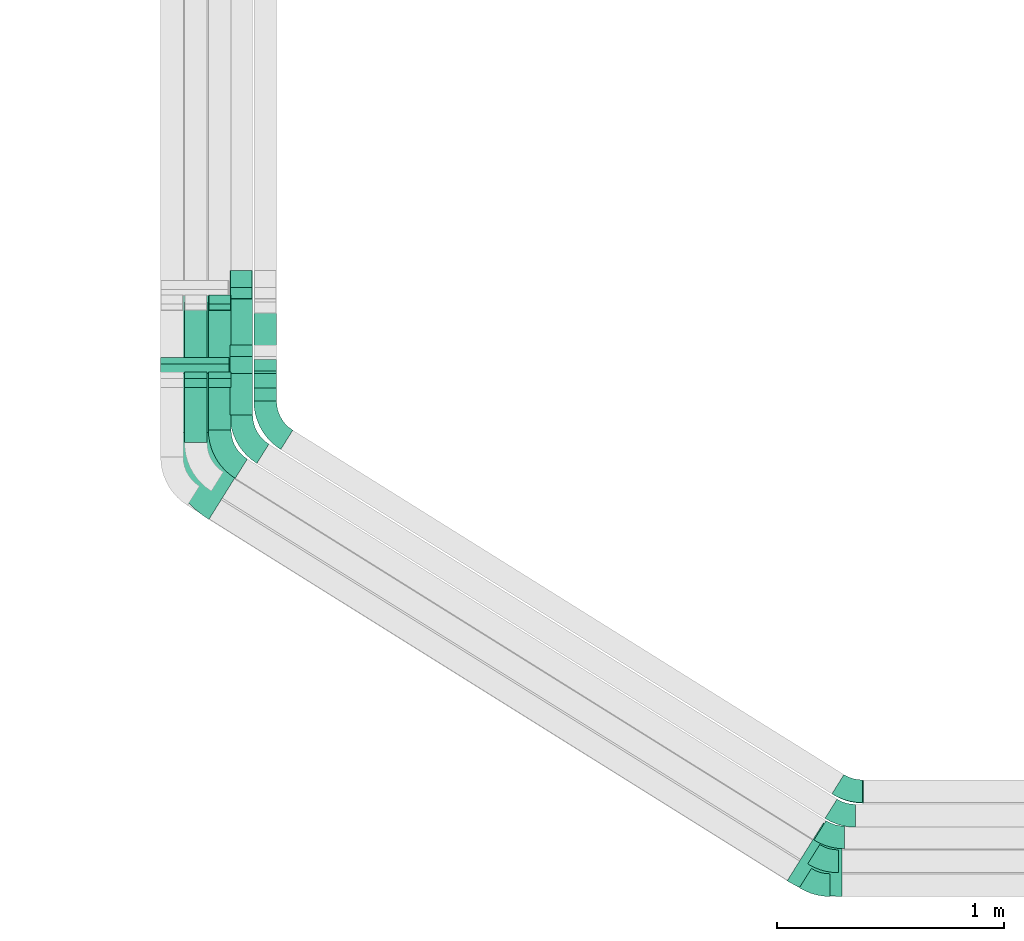
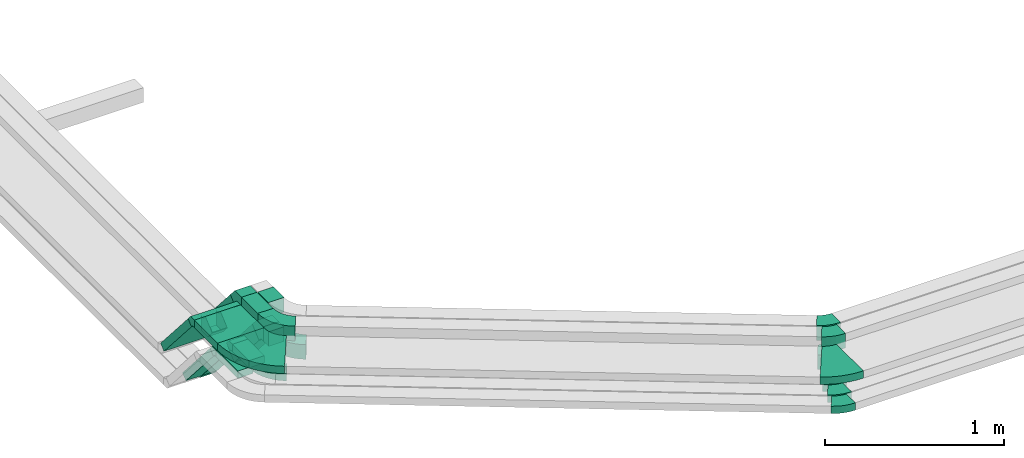
# One storey, part 4 of 18: 18 flow fittings, 11 flow segments.
"""IFC2X3 building model written with IfcOpenShell, lengths in millimetres."""

from ifc_helpers import new_model, entity, si_unit, converted_unit, derived_unit, direction, frame, frame_2d, origin, origin_2d_with_axis, place, context, subcontext, project, spatial, polyline, circle_curve, parameter, trimmed, segment, composite_curve, rectangle, outline, extrude, faceted_brep, source, transform, mapped, material, type_object, type_shapes, element, save


model = new_model("IFC2X3")

# Units and contexts
model_context = context("Model", 3, precision=0.01, world=origin(), true_north=direction((6.12303176911189e-17, 1.0)))
body_context = subcontext(model_context, "Body", "Model", "MODEL_VIEW")
ifc_project = project(units=[si_unit("LENGTHUNIT", "METRE", prefix="MILLI"), si_unit("AREAUNIT", "SQUARE_METRE"), si_unit("VOLUMEUNIT", "CUBIC_METRE"), converted_unit("PLANEANGLEUNIT", "DEGREE", entity("IfcRatioMeasure", 0.0174532925199433), si_unit("PLANEANGLEUNIT", "RADIAN"), dimensions=[0, 0, 0, 0, 0, 0, 0]), si_unit("MASSUNIT", "GRAM", prefix="KILO"), derived_unit("MASSDENSITYUNIT", [(si_unit("MASSUNIT", "GRAM", prefix="KILO"), 1), (si_unit("LENGTHUNIT", "METRE"), -3)]), derived_unit("MOMENTOFINERTIAUNIT", [(si_unit("LENGTHUNIT", "METRE"), 4)]), si_unit("TIMEUNIT", "SECOND"), si_unit("FREQUENCYUNIT", "HERTZ"), si_unit("THERMODYNAMICTEMPERATUREUNIT", "DEGREE_CELSIUS"), derived_unit("THERMALTRANSMITTANCEUNIT", [(si_unit("MASSUNIT", "GRAM", prefix="KILO"), 1), (si_unit("THERMODYNAMICTEMPERATUREUNIT", "KELVIN"), -1), (si_unit("TIMEUNIT", "SECOND"), -3)]), derived_unit("VOLUMETRICFLOWRATEUNIT", [(si_unit("LENGTHUNIT", "METRE"), 3), (si_unit("TIMEUNIT", "SECOND"), -1)]), derived_unit("MASSFLOWRATEUNIT", [(si_unit("MASSUNIT", "GRAM", prefix="KILO"), 1), (si_unit("TIMEUNIT", "SECOND"), -1)]), derived_unit("ROTATIONALFREQUENCYUNIT", [(si_unit("TIMEUNIT", "SECOND"), -1)]), si_unit("ELECTRICCURRENTUNIT", "AMPERE"), si_unit("ELECTRICVOLTAGEUNIT", "VOLT"), si_unit("POWERUNIT", "WATT"), si_unit("FORCEUNIT", "NEWTON", prefix="KILO"), si_unit("ILLUMINANCEUNIT", "LUX"), si_unit("LUMINOUSFLUXUNIT", "LUMEN"), si_unit("LUMINOUSINTENSITYUNIT", "CANDELA"), derived_unit("USERDEFINED", [(si_unit("MASSUNIT", "GRAM", prefix="KILO"), -1), (si_unit("LENGTHUNIT", "METRE"), -2), (si_unit("TIMEUNIT", "SECOND"), 3), (si_unit("LUMINOUSFLUXUNIT", "LUMEN"), 1)]), derived_unit("LINEARVELOCITYUNIT", [(si_unit("LENGTHUNIT", "METRE"), 1), (si_unit("TIMEUNIT", "SECOND"), -1)]), si_unit("PRESSUREUNIT", "PASCAL"), derived_unit("USERDEFINED", [(si_unit("LENGTHUNIT", "METRE"), -2), (si_unit("MASSUNIT", "GRAM", prefix="KILO"), 1), (si_unit("TIMEUNIT", "SECOND"), -2)]), derived_unit("LINEARFORCEUNIT", [(si_unit("MASSUNIT", "GRAM", prefix="KILO"), 1), (si_unit("LENGTHUNIT", "METRE"), 1), (si_unit("TIMEUNIT", "SECOND"), -2), (si_unit("LENGTHUNIT", "METRE"), -1)]), derived_unit("PLANARFORCEUNIT", [(si_unit("MASSUNIT", "GRAM", prefix="KILO"), 1), (si_unit("LENGTHUNIT", "METRE"), 1), (si_unit("TIMEUNIT", "SECOND"), -2), (si_unit("LENGTHUNIT", "METRE"), -2)])], contexts=[model_context])

# Site, building, storey
site_placement = place(None, frame((0.0, -0.00077364408347762, 0.0)))
site = spatial("IfcSite", under=ifc_project, at=site_placement, CompositionType="ELEMENT")
building_placement = place(site_placement, origin())
building = spatial("IfcBuilding", under=site, at=building_placement, CompositionType="ELEMENT")
storey_placement = place(building_placement, frame((0.0, 0.0, 19800.0)))
storey = spatial("IfcBuildingStorey", under=building, at=storey_placement, CompositionType="ELEMENT", Elevation=19800.0)

# Flow segments
cable_carrier_segment_type = type_object("IfcCableCarrierSegmentType", PredefinedType="CABLETRAYSEGMENT")
flow_segment_1_placement = place(storey_placement, frame((18112.1440474966, 4082.6181847776, 3000.0)))
element("IfcFlowSegment", 1, at=flow_segment_1_placement, inside=storey, type_object=cable_carrier_segment_type, context=body_context, shape_type="SweptSolid", body=[
    extrude(rectangle(XDim=241.620714461309, YDim=99.9999999999989, at=frame_2d((0.0, -1.08357767203415e-12), x_axis=(1.0, 0.0))), frame((50.0, 120.81035723066, 0.0), z_axis=(0.0, 0.0, 1.0), x_axis=(0.0, 1.0, 0.0)), (0.0, 0.0, 1.0), 49.9999999999973),
])
flow_segment_2_placement = place(storey_placement, frame((18217.1440474966, 4139.24926094307, 3000.0)))
element("IfcFlowSegment", 2, at=flow_segment_2_placement, inside=storey, type_object=cable_carrier_segment_type, context=body_context, shape_type="SweptSolid", body=[
    extrude(rectangle(XDim=184.989638295838, YDim=99.9999999999989, at=frame_2d((0.0, -1.08357767203415e-12), x_axis=(1.0, 0.0))), frame((50.0, 92.4948191479257, 0.0), z_axis=(0.0, 0.0, 1.0), x_axis=(0.0, 1.0, 0.0)), (0.0, 0.0, 1.0), 49.999999999993),
])
flow_segment_3_placement = place(storey_placement, frame((18417.1440474966, 4266.16565358375, 3000.0)))
element("IfcFlowSegment", 3, at=flow_segment_3_placement, inside=storey, type_object=cable_carrier_segment_type, context=body_context, shape_type="SweptSolid", body=[
    extrude(rectangle(XDim=57.0191013239463, YDim=99.9999999999989, at=frame_2d((2.70006239588838e-13, 1.08357767203415e-12), x_axis=(1.0, 0.0))), frame((50.0, 28.5095506619832, 0.0), z_axis=(0.0, 0.0, 1.0), x_axis=(0.0, 1.0, 0.0)), (0.0, 0.0, 1.0), 100.000000000008),
])
flow_segment_4_placement = place(storey_placement, frame((18112.1440474966, 4355.16048179056, 2631.28882558187)))
element("IfcFlowSegment", 4, at=flow_segment_4_placement, inside=storey, type_object=cable_carrier_segment_type, context=body_context, shape_type="SweptSolid", body=[
    extrude(rectangle(XDim=49.999999999999, YDim=99.9999999999989, at=frame_2d((-2.04281036531029e-13, 0.0), x_axis=(1.0, 0.0))), frame((50.0, 327.133678626219, 16.4014757247622), z_axis=(0.0, -0.656059028990503, 0.754709580222776), x_axis=(0.0, 0.754709580222776, 0.656059028990503)), (0.0, 0.0, 1.0), 469.87530923093),
])
flow_segment_5_placement = place(storey_placement, frame((18217.1440474966, 4355.16048179056, 2631.28882558187)))
element("IfcFlowSegment", 5, at=flow_segment_5_placement, inside=storey, type_object=cable_carrier_segment_type, context=body_context, shape_type="SweptSolid", body=[
    extrude(rectangle(XDim=49.999999999999, YDim=99.9999999999989, at=frame_2d((-2.04281036531029e-13, 2.16715534406831e-12), x_axis=(1.0, 0.0))), frame((50.0, 327.133678626218, 16.4014757247622), z_axis=(0.0, -0.656059028990503, 0.754709580222776), x_axis=(0.0, 0.754709580222776, 0.656059028990503)), (0.0, 0.0, 1.0), 469.87530923093),
])
flow_segment_6_placement = place(storey_placement, frame((18417.1440474966, 4372.97407696492, 2657.08439840759)))
element("IfcFlowSegment", 6, at=flow_segment_6_placement, inside=storey, type_object=cable_carrier_segment_type, context=body_context, shape_type="SweptSolid", body=[
    extrude(rectangle(XDim=99.9999999999987, YDim=99.9999999999989, at=origin_2d_with_axis()), frame((50.0, 316.103085662766, 32.8029514495245), z_axis=(0.0, -0.656059028990498, 0.75470958022278), x_axis=(0.0, 0.75470958022278, 0.656059028990498)), (0.0, 0.0, 1.0), 424.302683677664),
])
flow_segment_7_placement = place(storey_placement, frame((18007.1440474966, 4128.04598957686, 3200.0)))
element("IfcFlowSegment", 7, at=flow_segment_7_placement, inside=storey, type_object=cable_carrier_segment_type, context=body_context, shape_type="SweptSolid", body=[
    extrude(rectangle(XDim=259.517993750342, YDim=300.000000000001, at=origin_2d_with_axis()), frame((150.0, 129.758996875171, 0.0), z_axis=(0.0, 0.0, 1.0), x_axis=(0.0, 1.0, 0.0)), (0.0, 0.0, 1.0), 49.9999999999973),
])
flow_segment_8_placement = place(storey_placement, frame((18007.1440474966, 4418.48556587883, 2831.28882558187)))
element("IfcFlowSegment", 8, at=flow_segment_8_placement, inside=storey, type_object=cable_carrier_segment_type, context=body_context, shape_type="SweptSolid", body=[
    extrude(rectangle(XDim=49.999999999999, YDim=300.000000000001, at=frame_2d((4.10338429901458e-13, 0.0), x_axis=(1.0, 0.0))), frame((150.0, 327.133678626233, 16.4014757247709), z_axis=(0.0, -0.656059028990503, 0.754709580222776), x_axis=(0.0, 0.754709580222776, 0.656059028990503)), (0.0, 0.0, 1.0), 469.875309230929),
])
flow_segment_9_placement = place(storey_placement, frame((18312.1440474966, 4205.09736371012, 3200.0)))
element("IfcFlowSegment", 9, at=flow_segment_9_placement, inside=storey, type_object=cable_carrier_segment_type, context=body_context, shape_type="SweptSolid", body=[
    extrude(rectangle(XDim=181.412475285859, YDim=99.9999999999989, at=frame_2d((2.70006239588838e-13, 0.0), x_axis=(1.0, 0.0))), frame((50.0, 90.706237642931, 0.0), z_axis=(0.0, 0.0, 1.0), x_axis=(0.0, 1.0, 0.0)), (0.0, 0.0, 1.0), 100.000000000003),
])
flow_segment_10_placement = place(storey_placement, frame((18312.1440474966, 4436.29916105319, 2857.08439840759)))
element("IfcFlowSegment", 10, at=flow_segment_10_placement, inside=storey, type_object=cable_carrier_segment_type, context=body_context, shape_type="SweptSolid", body=[
    extrude(rectangle(XDim=99.9999999999979, YDim=99.9999999999989, at=origin_2d_with_axis()), frame((50.0, 316.103085662771, 32.8029514495245), z_axis=(0.0, -0.656059028990503, 0.754709580222776), x_axis=(0.0, 0.754709580222776, 0.656059028990503)), (0.0, 0.0, 1.0), 424.302683677666),
])
flow_segment_11_placement = place(storey_placement, frame((18417.1440474966, 4266.16565358379, 3200.0)))
element("IfcFlowSegment", 11, at=flow_segment_11_placement, inside=storey, type_object=cable_carrier_segment_type, context=body_context, shape_type="SweptSolid", body=[
    extrude(rectangle(XDim=120.344185412181, YDim=99.9999999999989, at=frame_2d((2.70006239588838e-13, 0.0), x_axis=(1.0, 0.0))), frame((50.0, 60.1720927060936, 0.0), z_axis=(0.0, 0.0, 1.0), x_axis=(0.0, 1.0, 0.0)), (0.0, 0.0, 1.0), 100.000000000008),
])

# Flow fittings
ifc_material = material()
cable_carrier_fitting_type_1 = type_object("IfcCableCarrierFittingType", Name="470_DKC_S5_Variable Angle Elbow 0-45:-", PredefinedType="NOTDEFINED", material=ifc_material)
shared_shape_1 = source(origin(), body_context, "Body", "SweptSolid", [
    extrude(outline(composite_curve([segment(polyline([(-53.9539384473602, -65.3276702004164), (-52.9539384473589, -65.3276702004164)]), True, "CONTINUOUS"), segment(trimmed(circle_curve(frame_2d((-52.9539384473615, 184.672329799583), x_axis=(0.0, -1.0)), 250.0), [parameter(0.0)], [parameter(32.0000000000001)], True, "PARAMETER"), True, "CONTINUOUS"), segment(polyline([(79.5258776109423, -27.3396942395212), (80.3739257070985, -26.8097749752882)]), True, "CONTINUOUS"), segment(polyline([(80.3739257070985, -26.8097749752881), (27.3819992837774, 57.995034640354)]), True, "CONTINUOUS"), segment(polyline([(27.3819992837774, 57.995034640354), (26.5339511876208, 57.4651153761206)]), True, "CONTINUOUS"), segment(trimmed(circle_curve(frame_2d((-52.9539384473615, 184.672329799583), x_axis=(0.0, -1.0)), 150.0), [parameter(0.0)], [parameter(32.0000000000001)], True, "PARAMETER"), False, "CONTINUOUS"), segment(polyline([(-52.9539384473597, 34.6723297995835), (-53.953938447361, 34.6723297995835)]), True, "CONTINUOUS"), segment(polyline([(-53.953938447361, 34.6723297995835), (-53.9539384473602, -65.3276702004164)]), True, "CONTINUOUS")], self_intersect=False)), frame((-4.39513870439234, 15.3276702004079, -50.0)), (0.0, 0.0, 1.0), 100.0),
])
type_shapes(cable_carrier_fitting_type_1, [shared_shape_1])
for number, where, z_axis, x_axis, name in (
    (12, (21038.9389178804, 2547.26804939277, 3050.0), (0.0, 0.0, 1.0), (0.848048096156425, -0.529919264233207, 0.0), "470_DKC_S5_Variable Angle Elbow 0-45:-"),
    (13, (21004.2443505154, 2442.26804939278, 3250.0), (0.0, 0.0, 1.0), (0.848048096156423, -0.52991926423321, 0.0), "470_DKC_S5_Variable Angle Elbow 0-45:-"),
    (14, (21034.567045744, 2549.99989830126, 3250.0), (0.0, 0.0, 1.0), (0.848048096156423, -0.52991926423321, 0.0), "470_DKC_S5_Variable Angle Elbow 0-45:-"),
):
    element("IfcFlowFitting", number, at=place(storey_placement, frame(where, z_axis=z_axis, x_axis=x_axis)), inside=storey, type_object=cable_carrier_fitting_type_1, material=ifc_material, Name=name, ObjectType="470_DKC_S5_Variable Angle Elbow 0-45:-", context=body_context, shape_type="MappedRepresentation", body=[
        mapped(shared_shape_1, transform((0.0, 0.0, 0.0), scale=1.0)),
    ])
cable_carrier_fitting_type_2 = type_object("IfcCableCarrierFittingType", Name="470_DKC_S5_Variable Angle Elbow 0-45:-", PredefinedType="NOTDEFINED", material=ifc_material)
shared_shape_2 = source(origin(), body_context, "Body", "SweptSolid", [
    extrude(outline(composite_curve([segment(polyline([(-53.9539384473611, -65.3276702004161), (-52.9539384473598, -65.3276702004161)]), True, "CONTINUOUS"), segment(trimmed(circle_curve(frame_2d((-52.9539384473602, 184.672329799584), x_axis=(0.0, -1.0)), 250.0), [parameter(0.0)], [parameter(32.0000000000003)], True, "PARAMETER"), True, "CONTINUOUS"), segment(polyline([(79.5258776109425, -27.3396942395216), (80.3739257070989, -26.8097749752884)]), True, "CONTINUOUS"), segment(polyline([(80.3739257070989, -26.8097749752884), (27.3819992837779, 57.9950346403538)]), True, "CONTINUOUS"), segment(polyline([(27.3819992837779, 57.9950346403537), (26.5339511876214, 57.4651153761205)]), True, "CONTINUOUS"), segment(trimmed(circle_curve(frame_2d((-52.9539384473602, 184.672329799584), x_axis=(0.0, -1.0)), 150.0), [parameter(0.0)], [parameter(32.0000000000003)], True, "PARAMETER"), False, "CONTINUOUS"), segment(polyline([(-52.9539384473598, 34.6723297995838), (-53.9539384473611, 34.6723297995838)]), True, "CONTINUOUS"), segment(polyline([(-53.9539384473611, 34.6723297995838), (-53.9539384473611, -65.3276702004161)]), True, "CONTINUOUS")], self_intersect=False)), frame((-4.39513870439244, 15.327670200408, -25.0)), (0.0, 0.0, 1.0), 50.0),
])
type_shapes(cable_carrier_fitting_type_2, [shared_shape_2])
for number, where, z_axis, x_axis, name in (
    (15, (20955.8971382444, 2347.26804939277, 3025.0), (0.0, 0.0, 1.0), (0.848048096156423, -0.52991926423321, 0.0), "470_DKC_S5_Variable Angle Elbow 0-45:-"),
    (16, (20928.3035971894, 2242.26804939277, 3025.0), (0.0, 0.0, 1.0), (0.848048096156423, -0.52991926423321, 0.0), "470_DKC_S5_Variable Angle Elbow 0-45:-"),
    (17, (20891.6866703417, 2137.26804939277, 3025.0), (0.0, 0.0, 1.0), (0.848048096156423, -0.52991926423321, 0.0), "470_DKC_S5_Variable Angle Elbow 0-45:-"),
):
    element("IfcFlowFitting", number, at=place(storey_placement, frame(where, z_axis=z_axis, x_axis=x_axis)), inside=storey, type_object=cable_carrier_fitting_type_2, material=ifc_material, Name=name, ObjectType="470_DKC_S5_Variable Angle Elbow 0-45:-", context=body_context, shape_type="MappedRepresentation", body=[
        mapped(shared_shape_2, transform((0.0, 0.0, 0.0), scale=1.0)),
    ])
cable_carrier_fitting_type_3 = type_object("IfcCableCarrierFittingType", Name="470_DKC_S5_Variable Angle Elbow 0-45:-", PredefinedType="NOTDEFINED", material=ifc_material)
shared_shape_3 = source(origin(), body_context, "Body", "SweptSolid", [
    extrude(outline(composite_curve([segment(polyline([(-80.4499016590186, -172.925265392596), (-79.4499016590172, -172.925265392596)]), True, "CONTINUOUS"), segment(trimmed(circle_curve(frame_2d((-79.4499016590253, 277.074734607403), x_axis=(0.0, -1.0)), 450.0), [parameter(0.0)], [parameter(32.0000000000003)], True, "PARAMETER"), True, "CONTINUOUS"), segment(polyline([(159.013767245926, -104.546908662982), (159.861815342083, -104.016989398749)]), True, "CONTINUOUS"), segment(polyline([(159.861815342083, -104.016989398749), (0.886036072114065, 150.397439448174)]), True, "CONTINUOUS"), segment(polyline([(0.886036072114098, 150.397439448174), (0.03798797595827, 149.867520183942)]), True, "CONTINUOUS"), segment(trimmed(circle_curve(frame_2d((-79.4499016590253, 277.074734607403), x_axis=(0.0, -1.0)), 150.0), [parameter(0.0)], [parameter(32.0000000000003)], True, "PARAMETER"), False, "CONTINUOUS"), segment(polyline([(-79.4499016590223, 127.074734607404), (-80.4499016590237, 127.074734607404)]), True, "CONTINUOUS"), segment(polyline([(-80.4499016590237, 127.074734607404), (-80.4499016590186, -172.925265392596)]), True, "CONTINUOUS")], self_intersect=False)), frame((-6.57371406861295, 22.9252653925868, -25.0)), (0.0, 0.0, 1.0), 49.9999999999987),
])
type_shapes(cable_carrier_fitting_type_3, [shared_shape_3])
flow_fitting_1_placement = place(storey_placement, frame((20915.2969629533, 2237.26804939276, 3225.0), z_axis=(0.0, 0.0, 1.0), x_axis=(0.848048096156423, -0.529919264233209, 0.0)))
element("IfcFlowFitting", 18, at=flow_fitting_1_placement, inside=storey, type_object=cable_carrier_fitting_type_3, material=ifc_material, Name="470_DKC_S5_Variable Angle Elbow 0-45:-", ObjectType="470_DKC_S5_Variable Angle Elbow 0-45:-", context=body_context, shape_type="MappedRepresentation", body=[
    mapped(shared_shape_3, transform((0.0, 0.0, 0.0), scale=1.0)),
])
cable_carrier_fitting_type_4 = type_object("IfcCableCarrierFittingType", Name="470_DKC_S5_Variable Angle Elbow 0-45:-", PredefinedType="NOTDEFINED", material=ifc_material)
shared_shape_4 = source(origin(), body_context, "Body", "SweptSolid", [
    extrude(outline(composite_curve([segment(polyline([(-85.6872894317013, -97.2200856007182), (-84.6872894317002, -97.2200856007182)]), True, "CONTINUOUS"), segment(trimmed(circle_curve(frame_2d((-84.6872894317005, 152.779914399281), x_axis=(0.0, -1.0)), 250.0), [parameter(0.0)], [parameter(57.9999999999997)], True, "PARAMETER"), True, "CONTINUOUS"), segment(polyline([(127.324734607405, 20.3000983409794), (127.854653871638, 21.1481464371359)]), True, "CONTINUOUS"), segment(polyline([(127.854653871638, 21.1481464371359), (43.049844255996, 74.1400728604566)]), True, "CONTINUOUS"), segment(polyline([(43.049844255996, 74.1400728604566), (42.5199249917629, 73.2920247643002)]), True, "CONTINUOUS"), segment(trimmed(circle_curve(frame_2d((-84.6872894317005, 152.779914399281), x_axis=(0.0, -1.0)), 150.0), [parameter(0.0)], [parameter(57.9999999999997)], True, "PARAMETER"), False, "CONTINUOUS"), segment(polyline([(-84.6872894317002, 2.77991439928172), (-85.6872894317013, 2.77991439928172)]), True, "CONTINUOUS"), segment(polyline([(-85.6872894317013, 2.77991439928172), (-85.6872894317013, -97.2200856007182)]), True, "CONTINUOUS")], self_intersect=False)), frame((-26.1745208588429, 47.2200856007101, -25.0)), (0.0, 0.0, 1.0), 49.9999999999998),
])
type_shapes(cable_carrier_fitting_type_4, [shared_shape_4])
flow_fitting_2_placement = place(storey_placement, frame((18267.1440474966, 4027.38745065254, 3025.0), z_axis=(0.0, 0.0, 1.0), x_axis=(0.0, -1.0, 0.0)))
element("IfcFlowFitting", 19, at=flow_fitting_2_placement, inside=storey, type_object=cable_carrier_fitting_type_4, material=ifc_material, Name="470_DKC_S5_Variable Angle Elbow 0-45:-", ObjectType="470_DKC_S5_Variable Angle Elbow 0-45:-", context=body_context, shape_type="MappedRepresentation", body=[
    mapped(shared_shape_4, transform((0.0, 0.0, 0.0), scale=1.0)),
])
cable_carrier_fitting_type_5 = type_object("IfcCableCarrierFittingType", PredefinedType="NOTDEFINED", material=ifc_material)
shared_shape_5 = source(origin(), body_context, "Body", "Brep", [
    faceted_brep([(-30.0649440542927, -25.0, 50.0), (-30.0649440542926, 25.0, 50.0), (-30.0649440542926, 25.0, 47.4600000101635), (-30.0649440542927, -22.4600000101599, 47.4600000101635), (-30.0649440542927, -22.4600000101599, -47.4600000101565), (-30.0649440542926, 25.0, -47.4600000101565), (-30.0649440542926, 25.0, -50.0), (-30.0649440542927, -25.0, -50.0), (38.5921175084832, 6.28882558187459, 50.0), (38.5921175084832, 6.28882558187459, -50.0), (0.856638497343776, 39.091777031399, -50.0), (0.856638497343783, 39.091777031399, -47.4600000101565), (36.6751551823852, 7.95521550884487, -47.4600000101565), (36.6751551823852, 7.95521550884487, 47.4600000101635), (0.856638497343774, 39.091777031399, 47.4600000101635), (0.85663849734377, 39.091777031399, 50.0), (11.3931563883155, -25.0, 50.0), (-11.3931563883146, 25.0, 50.0), (-11.3931563883146, 25.0, 47.4600000101635), (10.2356117038927, -22.46000001016, 47.4600000101635), (10.2356117038927, -22.46000001016, -47.4600000101565), (-11.3931563883146, 25.0, -47.4600000101565), (-11.3931563883146, 25.0, -50.0), (11.3931563883153, -25.0, -50.0)], [[[0, 1, 2, 3, 4, 5, 6, 7]], [[8, 9, 10, 11, 12, 13, 14, 15]], [[1, 0, 16, 8, 15, 17]], [[2, 1, 17, 18]], [[3, 2, 18, 14, 13, 19]], [[4, 3, 19, 20]], [[5, 4, 20, 12, 11, 21]], [[6, 5, 21, 22]], [[7, 6, 22, 10, 9, 23]], [[0, 7, 23, 16]], [[18, 17, 15, 14]], [[20, 19, 13, 12]], [[22, 21, 11, 10]], [[16, 23, 9, 8]]]),
])
type_shapes(cable_carrier_fitting_type_5, [shared_shape_5])
for number, where, z_axis, x_axis in (
    (20, (18162.1440474966, 4354.30384329322, 3025.0), (1.0, 0.0, 0.0), (0.0, -0.656059028990493, 0.754709580222785)),
    (21, (18267.1440474966, 4354.30384329322, 3025.0), (1.0, 0.0, 0.0), (0.0, -0.656059028990493, 0.754709580222785)),
    (22, (18267.1440474966, 4702.01853841969, 2625.0), (1.0, 0.0, 0.0), (0.0, 0.656059028990493, -0.754709580222785)),
):
    element("IfcFlowFitting", number, at=place(storey_placement, frame(where, z_axis=z_axis, x_axis=x_axis)), inside=storey, type_object=cable_carrier_fitting_type_5, material=ifc_material, context=body_context, shape_type="MappedRepresentation", body=[
        mapped(shared_shape_5, transform((0.0, 0.0, 0.0), scale=1.0)),
    ])
cable_carrier_fitting_type_6 = type_object("IfcCableCarrierFittingType", Name="470_DKC_S5_Variable Angle Elbow 0-45:-", PredefinedType="NOTDEFINED", material=ifc_material)
shared_shape_6 = source(origin(), body_context, "Body", "SweptSolid", [
    extrude(outline(composite_curve([segment(polyline([(-85.6872894317007, -97.2200856007192), (-84.6872894316995, -97.2200856007192)]), True, "CONTINUOUS"), segment(trimmed(circle_curve(frame_2d((-84.687289431702, 152.77991439928), x_axis=(0.0, -1.0)), 250.0), [parameter(0.0)], [parameter(57.9999999999999)], True, "PARAMETER"), True, "CONTINUOUS"), segment(polyline([(127.324734607405, 20.3000983409809), (127.854653871638, 21.1481464371369)]), True, "CONTINUOUS"), segment(polyline([(127.854653871638, 21.1481464371369), (43.0498442559958, 74.1400728604577)]), True, "CONTINUOUS"), segment(polyline([(43.0498442559958, 74.1400728604576), (42.5199249917623, 73.2920247643008)]), True, "CONTINUOUS"), segment(trimmed(circle_curve(frame_2d((-84.687289431702, 152.77991439928), x_axis=(0.0, -1.0)), 150.0), [parameter(0.0)], [parameter(57.9999999999999)], True, "PARAMETER"), False, "CONTINUOUS"), segment(polyline([(-84.6872894317004, 2.77991439928066), (-85.6872894317016, 2.77991439928066)]), True, "CONTINUOUS"), segment(polyline([(-85.6872894317016, 2.77991439928066), (-85.6872894317007, -97.2200856007192)]), True, "CONTINUOUS")], self_intersect=False)), frame((-26.1745208588432, 47.2200856007104, -50.0)), (0.0, 0.0, 1.0), 100.0),
])
type_shapes(cable_carrier_fitting_type_6, [shared_shape_6])
for number, where, z_axis, x_axis, name in (
    (23, (18467.1440474966, 4154.30384329322, 3050.0), (0.0, 0.0, 1.0), (0.0, -1.0, 0.0), "470_DKC_S5_Variable Angle Elbow 0-45:-"),
    (24, (18362.1440474966, 4093.23555341958, 3250.0), (0.0, 0.0, 1.0), (0.0, -1.0, 0.0), "470_DKC_S5_Variable Angle Elbow 0-45:-"),
):
    element("IfcFlowFitting", number, at=place(storey_placement, frame(where, z_axis=z_axis, x_axis=x_axis)), inside=storey, type_object=cable_carrier_fitting_type_6, material=ifc_material, Name=name, ObjectType="470_DKC_S5_Variable Angle Elbow 0-45:-", context=body_context, shape_type="MappedRepresentation", body=[
        mapped(shared_shape_6, transform((0.0, 0.0, 0.0), scale=1.0)),
    ])
cable_carrier_fitting_type_7 = type_object("IfcCableCarrierFittingType", PredefinedType="NOTDEFINED", material=ifc_material)
shared_shape_7 = source(origin(), body_context, "Body", "Brep", [
    faceted_brep([(-52.8512568309224, -50.0, 50.0), (-52.851256830922, 50.0, 50.0), (-52.851256830922, 50.0, 47.4600000101635), (-52.8512568309224, -47.4600000101598, 47.4600000101635), (-52.8512568309224, -47.4600000101598, -47.4600000101565), (-52.851256830922, 50.0, -47.4600000101565), (-52.851256830922, 50.0, -50.0), (-52.8512568309224, -50.0, -50.0), (72.4090232485621, 7.08439840758769, 50.0), (72.4090232485621, 7.08439840758768, -50.0), (-3.06193477371679, 72.6903013066365, -50.0), (-3.06193477371682, 72.6903013066365, -47.4600000101565), (70.492060922464, 8.75078833455798, -47.4600000101565), (70.4920609224641, 8.75078833455797, 47.4600000101635), (-3.06193477371679, 72.6903013066365, 47.4600000101635), (-3.06193477371679, 72.6903013066365, 50.0), (22.7863127766305, -50.0, 50.0), (-22.7863127766296, 50.0, 50.0), (-22.7863127766296, 50.0, 47.4600000101635), (21.6287680922077, -47.4600000101601, 47.4600000101635), (21.6287680922077, -47.4600000101601, -47.4600000101565), (-22.7863127766296, 50.0, -47.4600000101565), (-22.7863127766296, 50.0, -50.0), (22.7863127766303, -50.0, -50.0)], [[[0, 1, 2, 3, 4, 5, 6, 7]], [[8, 9, 10, 11, 12, 13, 14, 15]], [[1, 0, 16, 8, 15, 17]], [[2, 1, 17, 18]], [[3, 2, 18, 14, 13, 19]], [[4, 3, 19, 20]], [[5, 4, 20, 12, 11, 21]], [[6, 5, 21, 22]], [[7, 6, 22, 10, 9, 23]], [[0, 7, 23, 16]], [[18, 17, 15, 14]], [[20, 19, 13, 12]], [[22, 21, 11, 10]], [[16, 23, 9, 8]]]),
])
type_shapes(cable_carrier_fitting_type_7, [shared_shape_7])
for number, where, z_axis, x_axis in (
    (25, (18467.1440474966, 4376.03601173863, 3050.0), (1.0, 0.0, 0.0), (0.0, -0.656059028990495, 0.754709580222783)),
    (26, (18362.1440474966, 4439.3610958269, 3250.0), (1.0, 0.0, 0.0), (0.0, -0.656059028990503, 0.754709580222776)),
    (27, (18362.1440474966, 4787.07579095338, 2850.0), (1.0, 0.0, 0.0), (0.0, 0.656059028990503, -0.754709580222776)),
):
    element("IfcFlowFitting", number, at=place(storey_placement, frame(where, z_axis=z_axis, x_axis=x_axis)), inside=storey, type_object=cable_carrier_fitting_type_7, material=ifc_material, context=body_context, shape_type="MappedRepresentation", body=[
        mapped(shared_shape_7, transform((0.0, 0.0, 0.0), scale=1.0)),
    ])
cable_carrier_fitting_type_8 = type_object("IfcCableCarrierFittingType", Name="470_DKC_S5_Variable Angle Elbow 0-45:-", PredefinedType="NOTDEFINED", material=ifc_material)
shared_shape_8 = source(origin(), body_context, "Body", "SweptSolid", [
    extrude(outline(composite_curve([segment(polyline([(-128.089694239519, -220.72412238906), (-127.089694239517, -220.72412238906)]), True, "CONTINUOUS"), segment(trimmed(circle_curve(frame_2d((-127.089694239525, 229.27587761094), x_axis=(0.0, -1.0)), 450.0), [parameter(0.0)], [parameter(57.9999999999996)], True, "PARAMETER"), True, "CONTINUOUS"), segment(polyline([(254.531949030868, -9.18779129399819), (255.061868295101, -8.33974319784232)]), True, "CONTINUOUS"), segment(polyline([(255.061868295101, -8.33974319784228), (0.647439448172565, 150.636036072118)]), True, "CONTINUOUS"), segment(polyline([(0.647439448172586, 150.636036072118), (0.117520183939038, 149.787987975961)]), True, "CONTINUOUS"), segment(trimmed(circle_curve(frame_2d((-127.089694239525, 229.27587761094), x_axis=(0.0, -1.0)), 150.0), [parameter(0.0)], [parameter(57.9999999999996)], True, "PARAMETER"), False, "CONTINUOUS"), segment(polyline([(-127.089694239522, 79.2758776109403), (-128.089694239524, 79.2758776109402)]), True, "CONTINUOUS"), segment(polyline([(-128.089694239524, 79.2758776109402), (-128.089694239519, -220.72412238906)]), True, "CONTINUOUS")], self_intersect=False)), frame((-39.2030211962978, 70.7241223890494, -25.0)), (0.0, 0.0, 1.0), 49.9999999999978),
])
type_shapes(cable_carrier_fitting_type_8, [shared_shape_8])
flow_fitting_3_placement = place(storey_placement, frame((18157.1440474966, 3960.75327414105, 3225.0), z_axis=(0.0, 0.0, 1.0), x_axis=(0.0, -1.0, 0.0)))
element("IfcFlowFitting", 28, at=flow_fitting_3_placement, inside=storey, type_object=cable_carrier_fitting_type_8, material=ifc_material, Name="470_DKC_S5_Variable Angle Elbow 0-45:-", ObjectType="470_DKC_S5_Variable Angle Elbow 0-45:-", context=body_context, shape_type="MappedRepresentation", body=[
    mapped(shared_shape_8, transform((0.0, 0.0, 0.0), scale=1.0)),
])
cable_carrier_fitting_type_9 = type_object("IfcCableCarrierFittingType", PredefinedType="NOTDEFINED", material=ifc_material)
shared_shape_9 = source(origin(), body_context, "Body", "Brep", [
    faceted_brep([(-30.0649440542933, -25.0, 150.0), (-30.0649440542931, 25.0, 150.0), (-30.0649440542931, 25.0, 147.460000010164), (-30.0649440542933, -22.4600000101599, 147.460000010164), (-30.0649440542933, -22.4600000101599, -147.460000010156), (-30.0649440542931, 25.0, -147.460000010156), (-30.0649440542931, 25.0, -150.0), (-30.0649440542933, -25.0, -150.0), (38.5921175084835, 6.28882558187574, 150.0), (38.5921175084835, 6.28882558187574, -150.0), (0.856638497343465, 39.0917770313994, -150.0), (0.856638497343465, 39.0917770313994, -147.460000010156), (36.6751551823854, 7.95521550884599, -147.460000010156), (36.6751551823854, 7.95521550884599, 147.460000010164), (0.856638497343467, 39.0917770313994, 147.460000010164), (0.856638497343465, 39.0917770313994, 150.0), (11.3931563883158, -25.0, 150.0), (-11.3931563883149, 25.0, 150.0), (-11.3931563883149, 25.0, 147.460000010164), (10.2356117038929, -22.46000001016, 147.460000010164), (10.235611703893, -22.46000001016, -147.460000010156), (-11.3931563883149, 25.0, -147.460000010156), (-11.3931563883149, 25.0, -150.0), (11.3931563883156, -25.0, -150.0)], [[[0, 1, 2, 3, 4, 5, 6, 7]], [[8, 9, 10, 11, 12, 13, 14, 15]], [[1, 0, 16, 8, 15, 17]], [[2, 1, 17, 18]], [[3, 2, 18, 14, 13, 19]], [[4, 3, 19, 20]], [[5, 4, 20, 12, 11, 21]], [[6, 5, 21, 22]], [[7, 6, 22, 10, 9, 23]], [[0, 7, 23, 16]], [[18, 17, 15, 14]], [[20, 19, 13, 12]], [[22, 21, 11, 10]], [[16, 23, 9, 8]]]),
])
type_shapes(cable_carrier_fitting_type_9, [shared_shape_9])
flow_fitting_4_placement = place(storey_placement, frame((18157.1440474966, 4417.62892738149, 3225.0), z_axis=(-1.0, 0.0, 0.0), x_axis=(0.0, 1.0, 0.0)))
element("IfcFlowFitting", 29, at=flow_fitting_4_placement, inside=storey, type_object=cable_carrier_fitting_type_9, material=ifc_material, context=body_context, shape_type="MappedRepresentation", body=[
    mapped(shared_shape_9, transform((0.0, 0.0, 0.0), scale=1.0)),
])

save(model, "model.ifc")
